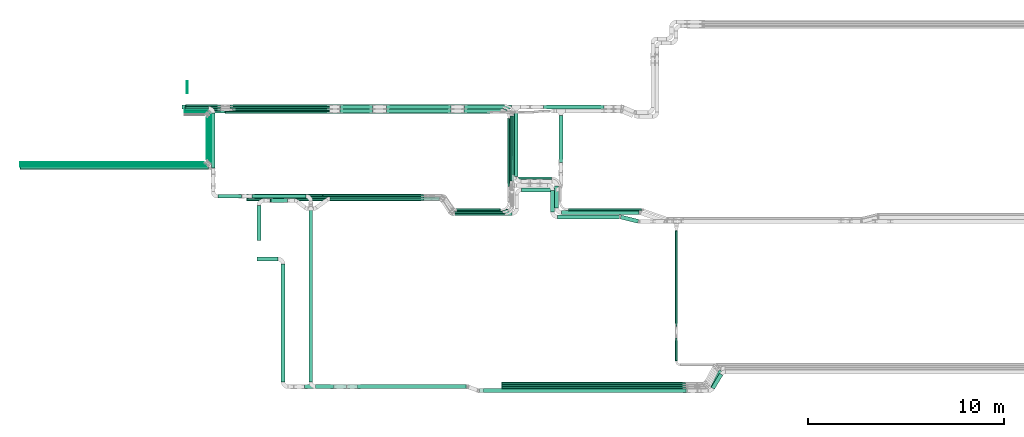
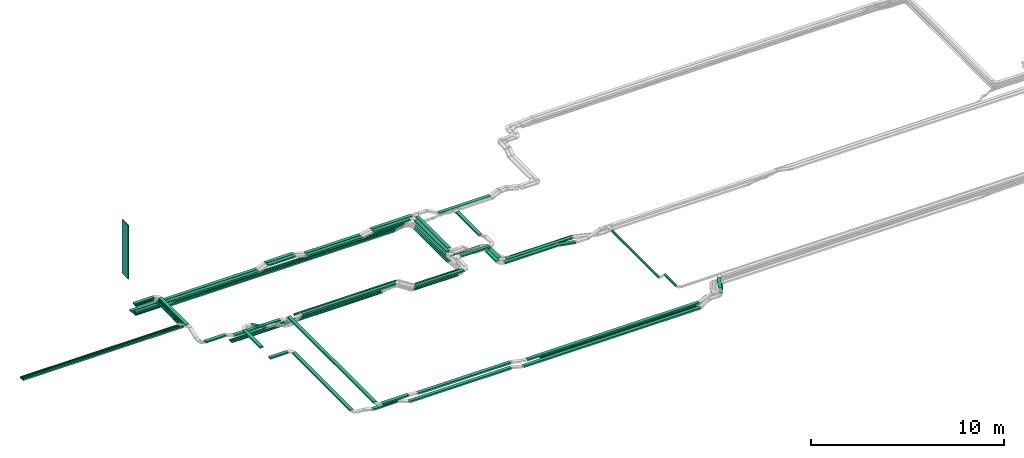
# One storey, part 1 of 23: 75 flow segments.
"""IFC2X3 building model written with IfcOpenShell, lengths in millimetres."""

from ifc_helpers import new_model, entity, si_unit, converted_unit, derived_unit, direction, frame, frame_2d, origin, origin_2d_with_axis, place, context, subcontext, project, spatial, rectangle, extrude, type_object, element, save


model = new_model("IFC2X3")

# Units and contexts
model_context = context("Model", 3, precision=0.01, world=origin(), true_north=direction((6.12303176911189e-17, 1.0)))
body_context = subcontext(model_context, "Body", "Model", "MODEL_VIEW")
ifc_project = project(units=[si_unit("LENGTHUNIT", "METRE", prefix="MILLI"), si_unit("AREAUNIT", "SQUARE_METRE"), si_unit("VOLUMEUNIT", "CUBIC_METRE"), converted_unit("PLANEANGLEUNIT", "DEGREE", entity("IfcRatioMeasure", 0.0174532925199433), si_unit("PLANEANGLEUNIT", "RADIAN"), dimensions=[0, 0, 0, 0, 0, 0, 0]), si_unit("MASSUNIT", "GRAM", prefix="KILO"), derived_unit("MASSDENSITYUNIT", [(si_unit("MASSUNIT", "GRAM", prefix="KILO"), 1), (si_unit("LENGTHUNIT", "METRE"), -3)]), derived_unit("MOMENTOFINERTIAUNIT", [(si_unit("LENGTHUNIT", "METRE"), 4)]), si_unit("TIMEUNIT", "SECOND"), si_unit("FREQUENCYUNIT", "HERTZ"), si_unit("THERMODYNAMICTEMPERATUREUNIT", "DEGREE_CELSIUS"), derived_unit("THERMALTRANSMITTANCEUNIT", [(si_unit("MASSUNIT", "GRAM", prefix="KILO"), 1), (si_unit("THERMODYNAMICTEMPERATUREUNIT", "KELVIN"), -1), (si_unit("TIMEUNIT", "SECOND"), -3)]), derived_unit("VOLUMETRICFLOWRATEUNIT", [(si_unit("LENGTHUNIT", "METRE"), 3), (si_unit("TIMEUNIT", "SECOND"), -1)]), derived_unit("MASSFLOWRATEUNIT", [(si_unit("MASSUNIT", "GRAM", prefix="KILO"), 1), (si_unit("TIMEUNIT", "SECOND"), -1)]), derived_unit("ROTATIONALFREQUENCYUNIT", [(si_unit("TIMEUNIT", "SECOND"), -1)]), si_unit("ELECTRICCURRENTUNIT", "AMPERE"), si_unit("ELECTRICVOLTAGEUNIT", "VOLT"), si_unit("POWERUNIT", "WATT"), si_unit("FORCEUNIT", "NEWTON", prefix="KILO"), si_unit("ILLUMINANCEUNIT", "LUX"), si_unit("LUMINOUSFLUXUNIT", "LUMEN"), si_unit("LUMINOUSINTENSITYUNIT", "CANDELA"), derived_unit("USERDEFINED", [(si_unit("MASSUNIT", "GRAM", prefix="KILO"), -1), (si_unit("LENGTHUNIT", "METRE"), -2), (si_unit("TIMEUNIT", "SECOND"), 3), (si_unit("LUMINOUSFLUXUNIT", "LUMEN"), 1)]), derived_unit("LINEARVELOCITYUNIT", [(si_unit("LENGTHUNIT", "METRE"), 1), (si_unit("TIMEUNIT", "SECOND"), -1)]), si_unit("PRESSUREUNIT", "PASCAL"), derived_unit("USERDEFINED", [(si_unit("LENGTHUNIT", "METRE"), -2), (si_unit("MASSUNIT", "GRAM", prefix="KILO"), 1), (si_unit("TIMEUNIT", "SECOND"), -2)]), derived_unit("LINEARFORCEUNIT", [(si_unit("MASSUNIT", "GRAM", prefix="KILO"), 1), (si_unit("LENGTHUNIT", "METRE"), 1), (si_unit("TIMEUNIT", "SECOND"), -2), (si_unit("LENGTHUNIT", "METRE"), -1)]), derived_unit("PLANARFORCEUNIT", [(si_unit("MASSUNIT", "GRAM", prefix="KILO"), 1), (si_unit("LENGTHUNIT", "METRE"), 1), (si_unit("TIMEUNIT", "SECOND"), -2), (si_unit("LENGTHUNIT", "METRE"), -2)])], contexts=[model_context])

# Site, building, storey
site_placement = place(None, origin())
site = spatial("IfcSite", under=ifc_project, at=site_placement, CompositionType="ELEMENT")
building_placement = place(site_placement, origin())
building = spatial("IfcBuilding", under=site, at=building_placement, CompositionType="ELEMENT")
storey_placement = place(building_placement, frame((0.0, 0.0, 24000.0)))
storey = spatial("IfcBuildingStorey", under=building, at=storey_placement, CompositionType="ELEMENT", Elevation=24000.0)

# Flow segments
cable_carrier_segment_type_1 = type_object("IfcCableCarrierSegmentType", PredefinedType="CABLETRAYSEGMENT")
flow_segment_1_placement = place(storey_placement, frame((18426.24, 14367.82, 2650.0)))
element("IfcFlowSegment", 1, at=flow_segment_1_placement, inside=storey, type_object=cable_carrier_segment_type_1, context=body_context, shape_type="SweptSolid", body=[
    extrude(rectangle(XDim=13495.0496959612, YDim=99.9999999999989, at=origin_2d_with_axis()), frame((6747.52, 50.0, 0.0), z_axis=(0.0, 0.0, 1.0), x_axis=(-1.0, 0.0, 0.0)), (0.0, 0.0, 1.0), 100.000000000003),
])
flow_segment_2_placement = place(storey_placement, frame((20056.24, 6814.78, 3300.0)))
element("IfcFlowSegment", 2, at=flow_segment_2_placement, inside=storey, type_object=cable_carrier_segment_type_1, context=body_context, shape_type="SweptSolid", body=[
    extrude(rectangle(XDim=1067.73986382415, YDim=200.0, at=origin_2d_with_axis()), frame((533.87, 100.0, 0.0)), (0.0, 0.0, 1.0), 100.000000000003),
])
flow_segment_3_placement = place(storey_placement, frame((21274.98, 666.0, 3300.0)))
element("IfcFlowSegment", 3, at=flow_segment_3_placement, inside=storey, type_object=cable_carrier_segment_type_1, context=body_context, shape_type="SweptSolid", body=[
    extrude(rectangle(XDim=5997.77664183526, YDim=199.999999999998, at=origin_2d_with_axis()), frame((100.0, 2998.89, 0.0), z_axis=(0.0, 0.0, 1.0), x_axis=(0.0, -1.0, 0.0)), (0.0, 0.0, 1.0), 100.000000000003),
])
flow_segment_4_placement = place(storey_placement, frame((16218.8, 14577.82, 2900.0)))
element("IfcFlowSegment", 4, at=flow_segment_4_placement, inside=storey, type_object=cable_carrier_segment_type_1, context=body_context, shape_type="SweptSolid", body=[
    extrude(rectangle(XDim=7528.07147672482, YDim=200.000000000002, at=origin_2d_with_axis()), frame((3764.04, 100.0, 0.0), z_axis=(0.0, 0.0, 1.0), x_axis=(-1.0, 0.0, 0.0)), (0.0, 0.0, 1.0), 100.000000000003),
])
flow_segment_5_placement = place(storey_placement, frame((19782.06, 10024.94, 2890.0)))
element("IfcFlowSegment", 5, at=flow_segment_5_placement, inside=storey, type_object=cable_carrier_segment_type_1, context=body_context, shape_type="SweptSolid", body=[
    extrude(rectangle(XDim=2751.91986939437, YDim=199.999999999998, at=origin_2d_with_axis()), frame((1375.96, 100.0, 0.0), z_axis=(0.0, 0.0, 1.0), x_axis=(-1.0, 0.0, 0.0)), (0.0, 0.0, 1.0), 99.9999999999989),
])
flow_segment_6_placement = place(storey_placement, frame((35435.62, 11850.48, 2650.0)))
element("IfcFlowSegment", 6, at=flow_segment_6_placement, inside=storey, type_object=cable_carrier_segment_type_1, context=body_context, shape_type="SweptSolid", body=[
    extrude(rectangle(XDim=2387.34330612991, YDim=199.999999999998, at=origin_2d_with_axis()), frame((100.0, 1193.67, 0.0), z_axis=(0.0, 0.0, 1.0), x_axis=(0.0, -1.0, 0.0)), (0.0, 0.0, 1.0), 100.000000000003),
])
flow_segment_7_placement = place(storey_placement, frame((33153.08, 11137.9, 3040.0)))
element("IfcFlowSegment", 7, at=flow_segment_7_placement, inside=storey, type_object=cable_carrier_segment_type_1, context=body_context, shape_type="SweptSolid", body=[
    extrude(rectangle(XDim=3309.92316772541, YDim=199.999999999998, at=origin_2d_with_axis()), frame((100.0, 1654.96, 0.0), z_axis=(0.0, 0.0, 1.0), x_axis=(0.0, 1.0, 0.0)), (0.0, 0.0, 1.0), 100.000000000003),
])
flow_segment_8_placement = place(storey_placement, frame((34655.69, 14577.82, 2650.0)))
element("IfcFlowSegment", 8, at=flow_segment_8_placement, inside=storey, type_object=cable_carrier_segment_type_1, context=body_context, shape_type="SweptSolid", body=[
    extrude(rectangle(XDim=3071.67344013226, YDim=199.999999999998, at=origin_2d_with_axis()), frame((1535.84, 100.0, 0.0), z_axis=(0.0, 0.0, 1.0), x_axis=(-1.0, 0.0, 0.0)), (0.0, 0.0, 1.0), 99.9999999999989),
])
flow_segment_9_placement = place(storey_placement, frame((16371.73, 14382.41, 3340.0)))
element("IfcFlowSegment", 9, at=flow_segment_9_placement, inside=storey, type_object=cable_carrier_segment_type_1, context=body_context, shape_type="SweptSolid", body=[
    extrude(rectangle(XDim=1072.92022544604, YDim=50.0000000000016, at=origin_2d_with_axis()), frame((536.46, 25.0, 0.0)), (0.0, 0.0, 1.0), 49.9999999999973),
])
flow_segment_10_placement = place(storey_placement, frame((17595.65, 11880.43, 3340.0)))
element("IfcFlowSegment", 10, at=flow_segment_10_placement, inside=storey, type_object=cable_carrier_segment_type_1, context=body_context, shape_type="SweptSolid", body=[
    extrude(rectangle(XDim=2350.98419120989, YDim=50.0000000000016, at=origin_2d_with_axis()), frame((25.0, 1175.49, 0.0), z_axis=(0.0, 0.0, 1.0), x_axis=(0.0, 1.0, 0.0)), (0.0, 0.0, 1.0), 49.9999999999973),
])
flow_segment_11_placement = place(storey_placement, frame((7960.65, 11679.43, 3340.0)))
element("IfcFlowSegment", 11, at=flow_segment_11_placement, inside=storey, type_object=cable_carrier_segment_type_1, context=body_context, shape_type="SweptSolid", body=[
    extrude(rectangle(XDim=9484.00000000001, YDim=50.0000000000016, at=origin_2d_with_axis()), frame((4742.0, 25.0, 0.0), z_axis=(0.0, 0.0, 1.0), x_axis=(-1.0, 0.0, 0.0)), (0.0, 0.0, 1.0), 49.9999999999973),
])
flow_segment_12_placement = place(storey_placement, frame((16371.73, 14447.74, 3340.0)))
element("IfcFlowSegment", 12, at=flow_segment_12_placement, inside=storey, type_object=cable_carrier_segment_type_1, context=body_context, shape_type="SweptSolid", body=[
    extrude(rectangle(XDim=1151.41871774957, YDim=50.0000000000016, at=origin_2d_with_axis()), frame((575.71, 25.0, 0.0)), (0.0, 0.0, 1.0), 49.9999999999973),
])
flow_segment_13_placement = place(storey_placement, frame((17653.15, 11820.43, 3340.0)))
element("IfcFlowSegment", 13, at=flow_segment_13_placement, inside=storey, type_object=cable_carrier_segment_type_1, context=body_context, shape_type="SweptSolid", body=[
    extrude(rectangle(XDim=2497.31331554762, YDim=50.0000000000016, at=origin_2d_with_axis()), frame((25.0, 1248.66, 0.0), z_axis=(0.0, 0.0, 1.0), x_axis=(0.0, 1.0, 0.0)), (0.0, 0.0, 1.0), 49.9999999999973),
])
flow_segment_14_placement = place(storey_placement, frame((7960.65, 11619.43, 3340.0)))
element("IfcFlowSegment", 14, at=flow_segment_14_placement, inside=storey, type_object=cable_carrier_segment_type_1, context=body_context, shape_type="SweptSolid", body=[
    extrude(rectangle(XDim=9541.49849230354, YDim=50.0000000000016, at=origin_2d_with_axis()), frame((4770.75, 25.0, 0.0), z_axis=(0.0, 0.0, 1.0), x_axis=(-1.0, 0.0, 0.0)), (0.0, 0.0, 1.0), 49.9999999999973),
])
flow_segment_15_placement = place(storey_placement, frame((16371.73, 14322.41, 3340.0)))
element("IfcFlowSegment", 15, at=flow_segment_15_placement, inside=storey, type_object=cable_carrier_segment_type_1, context=body_context, shape_type="SweptSolid", body=[
    extrude(rectangle(XDim=1033.92022544605, YDim=50.0000000000016, at=origin_2d_with_axis()), frame((516.96, 25.0, 0.0)), (0.0, 0.0, 1.0), 49.9999999999973),
])
flow_segment_16_placement = place(storey_placement, frame((17535.65, 11940.43, 3340.0)))
element("IfcFlowSegment", 16, at=flow_segment_16_placement, inside=storey, type_object=cable_carrier_segment_type_1, context=body_context, shape_type="SweptSolid", body=[
    extrude(rectangle(XDim=2251.98419120988, YDim=50.0000000000016, at=origin_2d_with_axis()), frame((25.0, 1125.99, 0.0), z_axis=(0.0, 0.0, 1.0), x_axis=(0.0, 1.0, 0.0)), (0.0, 0.0, 1.0), 49.9999999999973),
])
flow_segment_17_placement = place(storey_placement, frame((7960.65, 11739.43, 3340.0)))
element("IfcFlowSegment", 17, at=flow_segment_17_placement, inside=storey, type_object=cable_carrier_segment_type_1, context=body_context, shape_type="SweptSolid", body=[
    extrude(rectangle(XDim=9424.00000000001, YDim=50.0000000000016, at=origin_2d_with_axis()), frame((4712.0, 25.0, 0.0), z_axis=(0.0, 0.0, 1.0), x_axis=(-1.0, 0.0, 0.0)), (0.0, 0.0, 1.0), 49.9999999999973),
])
flow_segment_18_placement = place(storey_placement, frame((17475.65, 12000.43, 3340.0)))
element("IfcFlowSegment", 18, at=flow_segment_18_placement, inside=storey, type_object=cable_carrier_segment_type_1, context=body_context, shape_type="SweptSolid", body=[
    extrude(rectangle(XDim=2131.98419120988, YDim=50.0000000000016, at=origin_2d_with_axis()), frame((25.0, 1065.99, 0.0), z_axis=(0.0, 0.0, 1.0), x_axis=(0.0, 1.0, 0.0)), (0.0, 0.0, 1.0), 49.9999999999973),
])
flow_segment_19_placement = place(storey_placement, frame((7960.65, 11799.43, 3340.0)))
element("IfcFlowSegment", 19, at=flow_segment_19_placement, inside=storey, type_object=cable_carrier_segment_type_1, context=body_context, shape_type="SweptSolid", body=[
    extrude(rectangle(XDim=9364.00000000001, YDim=50.0000000000016, at=origin_2d_with_axis()), frame((4682.0, 25.0, 0.0), z_axis=(0.0, 0.0, 1.0), x_axis=(-1.0, 0.0, 0.0)), (0.0, 0.0, 1.0), 49.9999999999973),
])
flow_segment_20_placement = place(storey_placement, frame((26641.02, 14367.82, 2900.0)))
element("IfcFlowSegment", 20, at=flow_segment_20_placement, inside=storey, type_object=cable_carrier_segment_type_1, context=body_context, shape_type="SweptSolid", body=[
    extrude(rectangle(XDim=3294.43505749826, YDim=200.000000000002, at=origin_2d_with_axis()), frame((1647.22, 100.0, 0.0)), (0.0, 0.0, 1.0), 100.000000000003),
])
flow_segment_21_placement = place(storey_placement, frame((23395.46, 10107.82, 2890.0)))
element("IfcFlowSegment", 21, at=flow_segment_21_placement, inside=storey, type_object=cable_carrier_segment_type_1, context=body_context, shape_type="SweptSolid", body=[
    extrude(rectangle(XDim=6113.97273683925, YDim=99.9999999999989, at=origin_2d_with_axis()), frame((3056.99, 50.0, 0.0), z_axis=(0.0, 0.0, 1.0), x_axis=(-1.0, 0.0, 0.0)), (0.0, 0.0, 1.0), 100.000000000003),
])
flow_segment_22_placement = place(storey_placement, frame((41375.11, 3498.36, 2970.0)))
element("IfcFlowSegment", 22, at=flow_segment_22_placement, inside=storey, type_object=cable_carrier_segment_type_1, context=body_context, shape_type="SweptSolid", body=[
    extrude(rectangle(XDim=4876.63246763186, YDim=99.9999999999946, at=origin_2d_with_axis()), frame((50.0, 2438.32, 0.0), z_axis=(0.0, 0.0, 1.0), x_axis=(0.0, -1.0, 0.0)), (0.0, 0.0, 1.0), 100.000000000003),
])
flow_segment_23_placement = place(storey_placement, frame((7960.65, 11509.43, 3340.0)))
element("IfcFlowSegment", 23, at=flow_segment_23_placement, inside=storey, type_object=cable_carrier_segment_type_1, context=body_context, shape_type="SweptSolid", body=[
    extrude(rectangle(XDim=9622.49849230355, YDim=99.9999999999989, at=origin_2d_with_axis()), frame((4811.25, 50.0, 0.0), z_axis=(0.0, 0.0, 1.0), x_axis=(-1.0, 0.0, 0.0)), (0.0, 0.0, 1.0), 100.000000000003),
])
flow_segment_24_placement = place(storey_placement, frame((16371.73, 14507.74, 3340.0)))
element("IfcFlowSegment", 24, at=flow_segment_24_placement, inside=storey, type_object=cable_carrier_segment_type_1, context=body_context, shape_type="SweptSolid", body=[
    extrude(rectangle(XDim=1190.41871774959, YDim=200.000000000002, at=origin_2d_with_axis()), frame((595.21, 100.0, 0.0), z_axis=(0.0, 0.0, 1.0), x_axis=(-1.0, 0.0, 0.0)), (0.0, 0.0, 1.0), 100.000000000003),
])
flow_segment_25_placement = place(storey_placement, frame((17713.15, 11560.42, 3340.0)))
element("IfcFlowSegment", 25, at=flow_segment_25_placement, inside=storey, type_object=cable_carrier_segment_type_1, context=body_context, shape_type="SweptSolid", body=[
    extrude(rectangle(XDim=2796.32167346978, YDim=199.999999999998, at=origin_2d_with_axis()), frame((100.0, 1398.16, 0.0), z_axis=(0.0, 0.0, 1.0), x_axis=(0.0, -1.0, 0.0)), (0.0, 0.0, 1.0), 100.000000000003),
])
flow_segment_26_placement = place(storey_placement, frame((18043.15, 10024.94, 3074.68)))
element("IfcFlowSegment", 26, at=flow_segment_26_placement, inside=storey, type_object=cable_carrier_segment_type_1, context=body_context, shape_type="SweptSolid", body=[
    extrude(rectangle(XDim=1199.60118000453, YDim=200.000000000002, at=origin_2d_with_axis()), frame((599.8, 100.0, 0.0)), (0.0, 0.0, 1.0), 100.000000000003),
])
flow_segment_27_placement = place(storey_placement, frame((22684.98, 665.94, 3300.0)))
element("IfcFlowSegment", 27, at=flow_segment_27_placement, inside=storey, type_object=cable_carrier_segment_type_1, context=body_context, shape_type="SweptSolid", body=[
    extrude(rectangle(XDim=8953.99998500641, YDim=199.999999999998, at=origin_2d_with_axis()), frame((100.0, 4477.0, 0.0), z_axis=(0.0, -2.48714832989699e-07, 1.0), x_axis=(0.0, -1.0, -2.48714832989699e-07)), (0.0, 0.0, 1.0), 99.9999999999976),
])
flow_segment_28_placement = place(storey_placement, frame((25180.1, 315.0, 3225.21)))
element("IfcFlowSegment", 28, at=flow_segment_28_placement, inside=storey, type_object=cable_carrier_segment_type_1, context=body_context, shape_type="SweptSolid", body=[
    extrude(rectangle(XDim=5524.45942997487, YDim=200.0, at=origin_2d_with_axis()), frame((2762.23, 100.0, 0.0)), (0.0, 0.0, 1.0), 100.000000000003),
])
flow_segment_29_placement = place(storey_placement, frame((16371.73, 14367.82, 2900.0)))
element("IfcFlowSegment", 29, at=flow_segment_29_placement, inside=storey, type_object=cable_carrier_segment_type_1, context=body_context, shape_type="SweptSolid", body=[
    extrude(rectangle(XDim=7374.99679891814, YDim=200.000000000002, at=origin_2d_with_axis()), frame((3687.5, 100.0, 0.0)), (0.0, 0.0, 1.0), 100.000000000003),
])
flow_segment_30_placement = place(storey_placement, frame((24292.0, 14577.82, 3120.0)))
element("IfcFlowSegment", 30, at=flow_segment_30_placement, inside=storey, type_object=cable_carrier_segment_type_1, context=body_context, shape_type="SweptSolid", body=[
    extrude(rectangle(XDim=1637.51555642012, YDim=200.000000000002, at=origin_2d_with_axis()), frame((818.76, 100.0, 0.0), z_axis=(0.0, 0.0, 1.0), x_axis=(-1.0, 0.0, 0.0)), (0.0, 0.0, 1.0), 100.000000000003),
])
flow_segment_31_placement = place(storey_placement, frame((24285.07, 14367.82, 3120.0)))
element("IfcFlowSegment", 31, at=flow_segment_31_placement, inside=storey, type_object=cable_carrier_segment_type_1, context=body_context, shape_type="SweptSolid", body=[
    extrude(rectangle(XDim=1637.37746866894, YDim=200.000000000002, at=origin_2d_with_axis()), frame((818.69, 100.0, 0.0)), (0.0, 0.0, 1.0), 100.000000000003),
])
flow_segment_32_placement = place(storey_placement, frame((26648.08, 14577.82, 2900.0)))
element("IfcFlowSegment", 32, at=flow_segment_32_placement, inside=storey, type_object=cable_carrier_segment_type_1, context=body_context, shape_type="SweptSolid", body=[
    extrude(rectangle(XDim=3294.44624764002, YDim=200.000000000002, at=origin_2d_with_axis()), frame((1647.22, 100.0, 0.0)), (0.0, 0.0, 1.0), 100.000000000003),
])
flow_segment_33_placement = place(storey_placement, frame((24652.96, 315.0, 2875.21)))
element("IfcFlowSegment", 33, at=flow_segment_33_placement, inside=storey, type_object=cable_carrier_segment_type_1, context=body_context, shape_type="SweptSolid", body=[
    extrude(rectangle(XDim=6091.36072683295, YDim=200.0, at=origin_2d_with_axis()), frame((3045.68, 100.0, 0.0)), (0.0, 0.0, 1.0), 100.000000000003),
])
flow_segment_34_placement = place(storey_placement, frame((22469.25, 315.0, 3150.0)))
element("IfcFlowSegment", 34, at=flow_segment_34_placement, inside=storey, type_object=cable_carrier_segment_type_1, context=body_context, shape_type="SweptSolid", body=[
    extrude(rectangle(XDim=1469.63189251783, YDim=200.0, at=origin_2d_with_axis()), frame((734.82, 100.0, 0.0)), (0.0, 0.0, 1.0), 100.000000000003),
])
flow_segment_35_placement = place(storey_placement, frame((23035.98, 314.91, 3299.94)))
element("IfcFlowSegment", 35, at=flow_segment_35_placement, inside=storey, type_object=cable_carrier_segment_type_1, context=body_context, shape_type="SweptSolid", body=[
    extrude(rectangle(XDim=200.0, YDim=1559.04216988274, at=frame_2d((0.0, 0.0), x_axis=(0.0, 1.0))), frame((779.52, 100.06, 0.06), z_axis=(0.0, -0.000574637518698523, 0.999999834895847), x_axis=(1.0, 0.0, 0.0)), (0.0, 0.0, 1.0), 100.000000000004),
])
for number, where in (
    (36, (32519.4, 540.0, 2875.21)),
    (37, (32519.4, 430.0, 2875.21)),
):
    element("IfcFlowSegment", number, at=place(storey_placement, frame(where)), inside=storey, type_object=cable_carrier_segment_type_1, context=body_context, shape_type="SweptSolid", body=[
        extrude(rectangle(XDim=9371.15824609092, YDim=100.0, at=origin_2d_with_axis()), frame((4685.58, 50.0, 0.0)), (0.0, 0.0, 1.0), 49.9999999999973),
    ])
flow_segment_36_placement = place(storey_placement, frame((31591.02, 110.0, 3225.21)))
element("IfcFlowSegment", 38, at=flow_segment_36_placement, inside=storey, type_object=cable_carrier_segment_type_1, context=body_context, shape_type="SweptSolid", body=[
    extrude(rectangle(XDim=10314.9035127911, YDim=200.0, at=origin_2d_with_axis()), frame((5157.45, 100.0, 0.0)), (0.0, 0.0, 1.0), 100.000000000003),
])
flow_segment_37_placement = place(storey_placement, frame((32519.4, 320.0, 2875.21)))
element("IfcFlowSegment", 39, at=flow_segment_37_placement, inside=storey, type_object=cable_carrier_segment_type_1, context=body_context, shape_type="SweptSolid", body=[
    extrude(rectangle(XDim=9371.15824609091, YDim=100.0, at=origin_2d_with_axis()), frame((4685.58, 50.0, 0.0)), (0.0, 0.0, 1.0), 49.9999999999973),
])
flow_segment_38_placement = place(storey_placement, frame((31381.27, 110.0, 2875.21)))
element("IfcFlowSegment", 40, at=flow_segment_38_placement, inside=storey, type_object=cable_carrier_segment_type_1, context=body_context, shape_type="SweptSolid", body=[
    extrude(rectangle(XDim=10596.2476289759, YDim=200.0, at=origin_2d_with_axis()), frame((5298.12, 100.0, 0.0)), (0.0, 0.0, 1.0), 100.000000000003),
])
flow_segment_39_placement = place(storey_placement, frame((23778.09, 9897.82, 2890.0)))
element("IfcFlowSegment", 41, at=flow_segment_39_placement, inside=storey, type_object=cable_carrier_segment_type_1, context=body_context, shape_type="SweptSolid", body=[
    extrude(rectangle(XDim=5565.86907921064, YDim=200.000000000002, at=origin_2d_with_axis()), frame((2782.93, 100.0, 0.0), z_axis=(0.0, 0.0, 1.0), x_axis=(-1.0, 0.0, 0.0)), (0.0, 0.0, 1.0), 100.000000000003),
])
flow_segment_40_placement = place(storey_placement, frame((30125.7, 9147.82, 2890.0)))
element("IfcFlowSegment", 42, at=flow_segment_40_placement, inside=storey, type_object=cable_carrier_segment_type_1, context=body_context, shape_type="SweptSolid", body=[
    extrude(rectangle(XDim=2909.1864182489, YDim=200.0, at=origin_2d_with_axis()), frame((1454.59, 100.0, 0.0)), (0.0, 0.0, 1.0), 100.000000000003),
])
flow_segment_41_placement = place(storey_placement, frame((20036.87, 7874.72, 3351.74)))
element("IfcFlowSegment", 43, at=flow_segment_41_placement, inside=storey, type_object=cable_carrier_segment_type_1, context=body_context, shape_type="SweptSolid", body=[
    extrude(rectangle(XDim=1776.94785004133, YDim=199.999999999998, at=origin_2d_with_axis()), frame((100.0, 888.47, 0.0), z_axis=(0.0, 0.0, 1.0), x_axis=(0.0, 1.0, 0.0)), (0.0, 0.0, 1.0), 100.000000000003),
])
flow_segment_42_placement = place(storey_placement, frame((20706.06, 9802.66, 2902.85)))
element("IfcFlowSegment", 44, at=flow_segment_42_placement, inside=storey, type_object=cable_carrier_segment_type_1, context=body_context, shape_type="SweptSolid", body=[
    extrude(rectangle(XDim=100.0, YDim=200.000000000002, at=frame_2d((0.0, 0.0), x_axis=(0.0, 1.0))), frame((23.65, 100.0, 492.0), z_axis=(0.881037228424638, 0.0, -0.473046934383717), x_axis=(0.0, 1.0, 0.0)), (0.0, 0.0, 1.0), 946.942226981447),
])
flow_segment_43_placement = place(storey_placement, frame((30163.86, 9376.11, 2750.0)))
element("IfcFlowSegment", 45, at=flow_segment_43_placement, inside=storey, type_object=cable_carrier_segment_type_1, context=body_context, shape_type="SweptSolid", body=[
    extrude(rectangle(XDim=2289.22650689214, YDim=99.9999999999989, at=origin_2d_with_axis()), frame((1144.61, 50.0, 0.0)), (0.0, 0.0, 1.0), 49.9999999999973),
])
flow_segment_44_placement = place(storey_placement, frame((30095.97, 9266.11, 2750.0)))
element("IfcFlowSegment", 46, at=flow_segment_44_placement, inside=storey, type_object=cable_carrier_segment_type_1, context=body_context, shape_type="SweptSolid", body=[
    extrude(rectangle(XDim=2467.10974265438, YDim=99.9999999999989, at=origin_2d_with_axis()), frame((1233.55, 50.0, 0.0)), (0.0, 0.0, 1.0), 49.9999999999973),
])
flow_segment_45_placement = place(storey_placement, frame((30008.58, 9156.11, 2750.0)))
element("IfcFlowSegment", 47, at=flow_segment_45_placement, inside=storey, type_object=cable_carrier_segment_type_1, context=body_context, shape_type="SweptSolid", body=[
    extrude(rectangle(XDim=2664.50105408022, YDim=100.000000000001, at=origin_2d_with_axis()), frame((1332.25, 50.0, 0.0)), (0.0, 0.0, 1.0), 49.9999999999973),
])
flow_segment_46_placement = place(storey_placement, frame((19519.4, 9897.82, 2650.0)))
element("IfcFlowSegment", 48, at=flow_segment_46_placement, inside=storey, type_object=cable_carrier_segment_type_1, context=body_context, shape_type="SweptSolid", body=[
    extrude(rectangle(XDim=9035.28773953544, YDim=99.9999999999989, at=origin_2d_with_axis()), frame((4517.64, 50.0, 0.0)), (0.0, 0.0, 1.0), 50.0000000000016),
])
flow_segment_47_placement = place(storey_placement, frame((19519.4, 10007.82, 2650.0)))
element("IfcFlowSegment", 49, at=flow_segment_47_placement, inside=storey, type_object=cable_carrier_segment_type_1, context=body_context, shape_type="SweptSolid", body=[
    extrude(rectangle(XDim=9035.25711850963, YDim=99.9999999999989, at=origin_2d_with_axis()), frame((4517.63, 50.0, 0.0)), (0.0, 0.0, 1.0), 50.0000000000017),
])
flow_segment_48_placement = place(storey_placement, frame((19519.4, 10117.82, 2650.0)))
element("IfcFlowSegment", 50, at=flow_segment_48_placement, inside=storey, type_object=cable_carrier_segment_type_1, context=body_context, shape_type="SweptSolid", body=[
    extrude(rectangle(XDim=9035.33059198998, YDim=99.9999999999989, at=origin_2d_with_axis()), frame((4517.67, 50.0, 0.0)), (0.0, 0.0, 1.0), 50.0000000000017),
])
flow_segment_49_placement = place(storey_placement, frame((30609.74, 14367.82, 3040.0)))
element("IfcFlowSegment", 51, at=flow_segment_49_placement, inside=storey, type_object=cable_carrier_segment_type_1, context=body_context, shape_type="SweptSolid", body=[
    extrude(rectangle(XDim=2182.34389256264, YDim=200.000000000002, at=origin_2d_with_axis()), frame((1091.17, 100.0, 0.0), z_axis=(0.0, 0.0, 1.0), x_axis=(-1.0, 0.0, 0.0)), (0.0, 0.0, 1.0), 100.000000000003),
])
flow_segment_50_placement = place(storey_placement, frame((32833.08, 10611.48, 2650.0)))
element("IfcFlowSegment", 52, at=flow_segment_50_placement, inside=storey, type_object=cable_carrier_segment_type_1, context=body_context, shape_type="SweptSolid", body=[
    extrude(rectangle(XDim=3486.34704231681, YDim=100.000000000003, at=origin_2d_with_axis()), frame((50.0, 1743.17, 0.0), z_axis=(0.0, 0.0, 1.0), x_axis=(0.0, -1.0, 0.0)), (0.0, 0.0, 1.0), 49.9999999999973),
])
flow_segment_51_placement = place(storey_placement, frame((32943.08, 10611.48, 2650.0)))
element("IfcFlowSegment", 53, at=flow_segment_51_placement, inside=storey, type_object=cable_carrier_segment_type_1, context=body_context, shape_type="SweptSolid", body=[
    extrude(rectangle(XDim=3596.34704231681, YDim=100.000000000003, at=origin_2d_with_axis()), frame((50.0, 1798.17, 0.0), z_axis=(0.0, 0.0, 1.0), x_axis=(0.0, -1.0, 0.0)), (0.0, 0.0, 1.0), 49.9999999999973),
])
flow_segment_52_placement = place(storey_placement, frame((18785.32, 14477.82, 2650.0)))
element("IfcFlowSegment", 54, at=flow_segment_52_placement, inside=storey, type_object=cable_carrier_segment_type_1, context=body_context, shape_type="SweptSolid", body=[
    extrude(rectangle(XDim=13667.7601538151, YDim=99.9999999999989, at=origin_2d_with_axis()), frame((6833.88, 50.0, 0.0), z_axis=(0.0, 0.0, 1.0), x_axis=(-1.0, 0.0, 0.0)), (0.0, 0.0, 1.0), 49.9999999999973),
])
flow_segment_53_placement = place(storey_placement, frame((16399.4, 14587.82, 2700.0)))
element("IfcFlowSegment", 55, at=flow_segment_53_placement, inside=storey, type_object=cable_carrier_segment_type_1, context=body_context, shape_type="SweptSolid", body=[
    extrude(rectangle(XDim=1797.44094448676, YDim=99.9999999999989, at=origin_2d_with_axis()), frame((898.72, 50.0, 0.0), z_axis=(0.0, 0.0, 1.0), x_axis=(-1.0, 0.0, 0.0)), (0.0, 0.0, 1.0), 49.9999999999973),
])
flow_segment_54_placement = place(storey_placement, frame((16399.4, 14697.82, 2700.0)))
element("IfcFlowSegment", 56, at=flow_segment_54_placement, inside=storey, type_object=cable_carrier_segment_type_1, context=body_context, shape_type="SweptSolid", body=[
    extrude(rectangle(XDim=1797.44094448677, YDim=99.9999999999989, at=origin_2d_with_axis()), frame((898.72, 50.0, 0.0), z_axis=(0.0, 0.0, 1.0), x_axis=(-1.0, 0.0, 0.0)), (0.0, 0.0, 1.0), 49.9999999999973),
])
flow_segment_55_placement = place(storey_placement, frame((32943.08, 10906.9, 3040.0)))
element("IfcFlowSegment", 57, at=flow_segment_55_placement, inside=storey, type_object=cable_carrier_segment_type_1, context=body_context, shape_type="SweptSolid", body=[
    extrude(rectangle(XDim=3309.92316772554, YDim=199.999999999998, at=origin_2d_with_axis()), frame((100.0, 1654.96, 0.0), z_axis=(0.0, 0.0, 1.0), x_axis=(0.0, -1.0, 0.0)), (0.0, 0.0, 1.0), 100.000000000003),
])
flow_segment_56_placement = place(storey_placement, frame((30238.67, 9357.82, 2890.0)))
element("IfcFlowSegment", 58, at=flow_segment_56_placement, inside=storey, type_object=cable_carrier_segment_type_1, context=body_context, shape_type="SweptSolid", body=[
    extrude(rectangle(XDim=2603.41778768155, YDim=99.9999999999989, at=origin_2d_with_axis()), frame((1301.71, 50.0, 0.0)), (0.0, 0.0, 1.0), 100.000000000003),
])
flow_segment_57_placement = place(storey_placement, frame((33536.89, 10347.82, 2890.0)))
element("IfcFlowSegment", 59, at=flow_segment_57_placement, inside=storey, type_object=cable_carrier_segment_type_1, context=body_context, shape_type="SweptSolid", body=[
    extrude(rectangle(XDim=1747.73016943143, YDim=199.999999999998, at=origin_2d_with_axis()), frame((873.87, 100.0, 0.0)), (0.0, 0.0, 1.0), 100.000000000003),
])
flow_segment_58_placement = place(storey_placement, frame((35013.08, 9325.94, 2660.0)))
element("IfcFlowSegment", 60, at=flow_segment_58_placement, inside=storey, type_object=cable_carrier_segment_type_1, context=body_context, shape_type="SweptSolid", body=[
    extrude(rectangle(XDim=1099.95785985898, YDim=199.999999999998, at=origin_2d_with_axis()), frame((100.0, 549.98, 0.0), z_axis=(0.0, 0.0, 1.0), x_axis=(0.0, -1.0, 0.0)), (0.0, 0.0, 1.0), 100.000000000003),
])
flow_segment_59_placement = place(storey_placement, frame((35364.08, 8974.94, 2660.0)))
element("IfcFlowSegment", 61, at=flow_segment_59_placement, inside=storey, type_object=cable_carrier_segment_type_1, context=body_context, shape_type="SweptSolid", body=[
    extrude(rectangle(XDim=3156.52524029667, YDim=200.0, at=origin_2d_with_axis()), frame((1578.26, 100.0, 0.0)), (0.0, 0.0, 1.0), 100.000000000003),
])
flow_segment_60_placement = place(storey_placement, frame((35223.08, 9535.94, 2660.0)))
element("IfcFlowSegment", 62, at=flow_segment_60_placement, inside=storey, type_object=cable_carrier_segment_type_1, context=body_context, shape_type="SweptSolid", body=[
    extrude(rectangle(XDim=1120.95785985897, YDim=199.999999999998, at=origin_2d_with_axis()), frame((100.0, 560.48, 0.0), z_axis=(0.0, 0.0, 1.0), x_axis=(0.0, -1.0, 0.0)), (0.0, 0.0, 1.0), 100.000000000003),
])
flow_segment_61_placement = place(storey_placement, frame((35574.08, 9184.94, 2660.0)))
element("IfcFlowSegment", 63, at=flow_segment_61_placement, inside=storey, type_object=cable_carrier_segment_type_1, context=body_context, shape_type="SweptSolid", body=[
    extrude(rectangle(XDim=3953.5852497596, YDim=200.0, at=origin_2d_with_axis()), frame((1976.79, 100.0, 0.0)), (0.0, 0.0, 1.0), 100.000000000003),
])
flow_segment_62_placement = place(storey_placement, frame((33053.08, 11226.9, 2650.0)))
element("IfcFlowSegment", 64, at=flow_segment_62_placement, inside=storey, type_object=cable_carrier_segment_type_1, context=body_context, shape_type="SweptSolid", body=[
    extrude(rectangle(XDim=3090.92316799697, YDim=99.999999991219, at=origin_2d_with_axis()), frame((50.0, 1545.46, 0.02), z_axis=(0.0, 1.32503353277792e-05, 1.0), x_axis=(0.0, -1.0, 1.32503353277792e-05)), (0.0, 0.0, 1.0), 49.999999995611),
])
flow_segment_63_placement = place(storey_placement, frame((33282.97, 10996.9, 2650.04)))
element("IfcFlowSegment", 65, at=flow_segment_63_placement, inside=storey, type_object=cable_carrier_segment_type_1, context=body_context, shape_type="SweptSolid", body=[
    extrude(rectangle(XDim=49.9999999999973, YDim=99.9999999999989, at=origin_2d_with_axis()), frame((0.11, 50.0, 25.0), z_axis=(0.999989846537598, 0.0, 0.00450630910082806), x_axis=(-0.00450630910082806, 0.0, 0.999989846537598)), (0.0, 0.0, 1.0), 1780.02243937971),
])
flow_segment_64_placement = place(storey_placement, frame((35923.08, 9394.94, 2660.0)))
element("IfcFlowSegment", 66, at=flow_segment_64_placement, inside=storey, type_object=cable_carrier_segment_type_1, context=body_context, shape_type="SweptSolid", body=[
    extrude(rectangle(XDim=3743.01383141403, YDim=100.000000000001, at=origin_2d_with_axis()), frame((1871.51, 50.0, 0.0)), (0.0, 0.0, 1.0), 49.9999999999973),
])
flow_segment_65_placement = place(storey_placement, frame((38558.93, 8745.66, 2660.0)))
element("IfcFlowSegment", 67, at=flow_segment_65_placement, inside=storey, type_object=cable_carrier_segment_type_1, context=body_context, shape_type="SweptSolid", body=[
    extrude(rectangle(XDim=926.743066728364, YDim=199.999999999995, at=origin_2d_with_axis()), frame((473.79, 209.3, 0.0), z_axis=(0.0, 0.0, 1.0), x_axis=(-0.970196742340564, 0.242318553048991, 0.0)), (0.0, 0.0, 1.0), 100.000000000003),
])
flow_segment_66_placement = place(storey_placement, frame((41375.11, 1730.69, 3517.23)))
element("IfcFlowSegment", 68, at=flow_segment_66_placement, inside=storey, type_object=cable_carrier_segment_type_1, context=body_context, shape_type="SweptSolid", body=[
    extrude(rectangle(XDim=1173.69946209604, YDim=99.9999999999946, at=origin_2d_with_axis()), frame((50.0, 586.85, 0.0), z_axis=(0.0, 0.0, 1.0), x_axis=(0.0, -1.0, 0.0)), (0.0, 0.0, 1.0), 100.000000000008),
])
flow_segment_67_placement = place(storey_placement, frame((43195.95, 281.31, 3217.23)))
element("IfcFlowSegment", 69, at=flow_segment_67_placement, inside=storey, type_object=cable_carrier_segment_type_1, context=body_context, shape_type="SweptSolid", body=[
    extrude(rectangle(XDim=832.336893352993, YDim=199.999999999996, at=origin_2d_with_axis()), frame((299.33, 408.54, 0.0), z_axis=(0.0, 0.0, 1.0), x_axis=(-0.512992652430847, -0.85839299773004, 0.0)), (0.0, 0.0, 1.0), 100.000000000003),
])
flow_segment_68_placement = place(storey_placement, frame((43162.69, 306.09, 3517.23)))
element("IfcFlowSegment", 70, at=flow_segment_68_placement, inside=storey, type_object=cable_carrier_segment_type_1, context=body_context, shape_type="SweptSolid", body=[
    extrude(rectangle(XDim=980.149325928577, YDim=200.000000000005, at=origin_2d_with_axis()), frame((306.45, 483.76, 0.0), z_axis=(0.0, 0.0, 1.0), x_axis=(-0.442315095835614, -0.896859719240379, 0.0)), (0.0, 0.0, 1.0), 100.000000000003),
])
flow_segment_69_placement = place(storey_placement, frame((30629.63, 14577.82, 3040.0)))
element("IfcFlowSegment", 71, at=flow_segment_69_placement, inside=storey, type_object=cable_carrier_segment_type_1, context=body_context, shape_type="SweptSolid", body=[
    extrude(rectangle(XDim=2393.45095108697, YDim=199.999999999998, at=origin_2d_with_axis()), frame((1196.73, 100.0, 0.0)), (0.0, 0.0, 1.0), 100.000000000003),
])
flow_segment_70_placement = place(storey_placement, frame((16399.4, 14477.82, 2700.0)))
element("IfcFlowSegment", 72, at=flow_segment_70_placement, inside=storey, type_object=cable_carrier_segment_type_1, context=body_context, shape_type="SweptSolid", body=[
    extrude(rectangle(XDim=1797.76015381485, YDim=99.9999999999989, at=origin_2d_with_axis()), frame((898.88, 50.0, 0.0)), (0.0, 0.0, 1.0), 49.9999999999973),
])
flow_segment_71_placement = place(storey_placement, frame((18665.64, 14587.82, 2650.0)))
element("IfcFlowSegment", 73, at=flow_segment_71_placement, inside=storey, type_object=cable_carrier_segment_type_1, context=body_context, shape_type="SweptSolid", body=[
    extrude(rectangle(XDim=13897.4409444871, YDim=99.9999999999989, at=origin_2d_with_axis()), frame((6948.72, 50.0, 0.0), z_axis=(0.0, 0.0, 1.0), x_axis=(-1.0, 0.0, 0.0)), (0.0, 0.0, 1.0), 49.9999999999973),
])
flow_segment_72_placement = place(storey_placement, frame((18665.64, 14697.82, 2650.0)))
element("IfcFlowSegment", 74, at=flow_segment_72_placement, inside=storey, type_object=cable_carrier_segment_type_1, context=body_context, shape_type="SweptSolid", body=[
    extrude(rectangle(XDim=14007.4409444871, YDim=99.9999999999989, at=origin_2d_with_axis()), frame((7003.72, 50.0, 0.0), z_axis=(0.0, 0.0, 1.0), x_axis=(-1.0, 0.0, 0.0)), (0.0, 0.0, 1.0), 49.9999999999973),
])
cable_carrier_segment_type_2 = type_object("IfcCableCarrierSegmentType", PredefinedType="CABLETRAYSEGMENT")
flow_segment_73_placement = place(storey_placement, frame((16472.31, 15387.61, 4425.84)))
element("IfcFlowSegment", 75, at=flow_segment_73_placement, inside=storey, type_object=cable_carrier_segment_type_2, context=body_context, shape_type="SweptSolid", body=[
    extrude(rectangle(XDim=50.0000000000016, YDim=599.999999999998, at=origin_2d_with_axis()), frame((25.0, 300.0, 0.0), z_axis=(0.0, 0.0, 1.0), x_axis=(-1.0, 0.0, 0.0)), (0.0, 0.0, 1.0), 3440.0),
])

save(model, "model.ifc")
